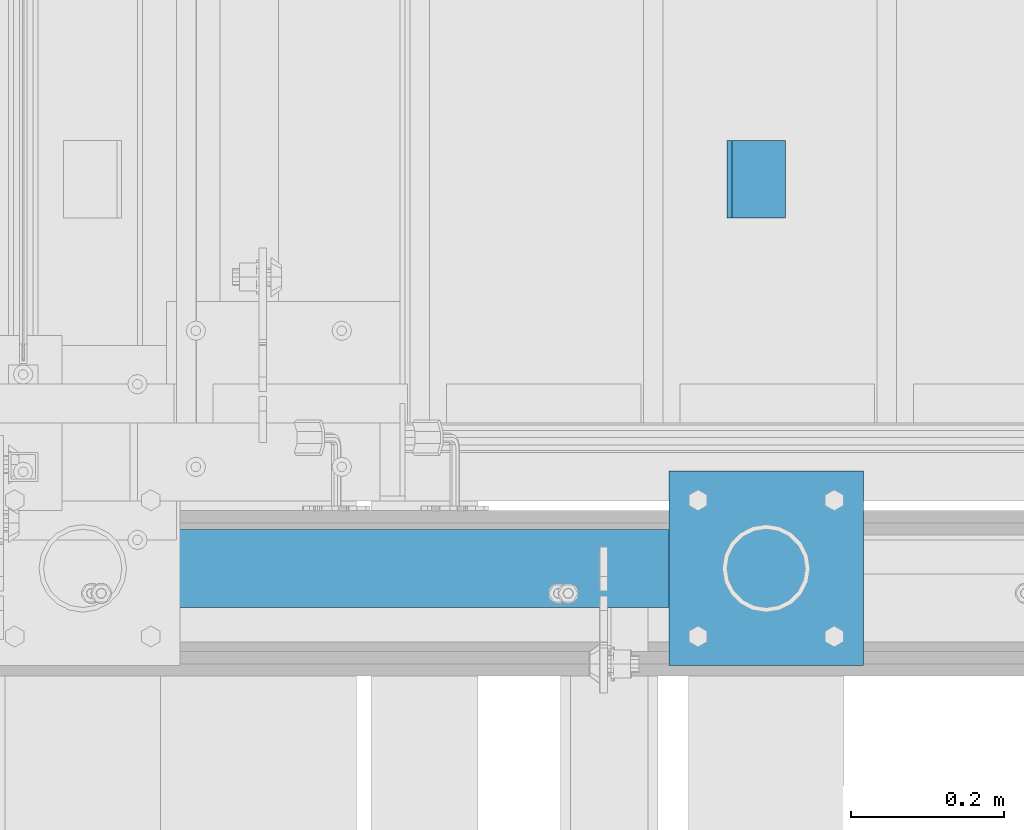
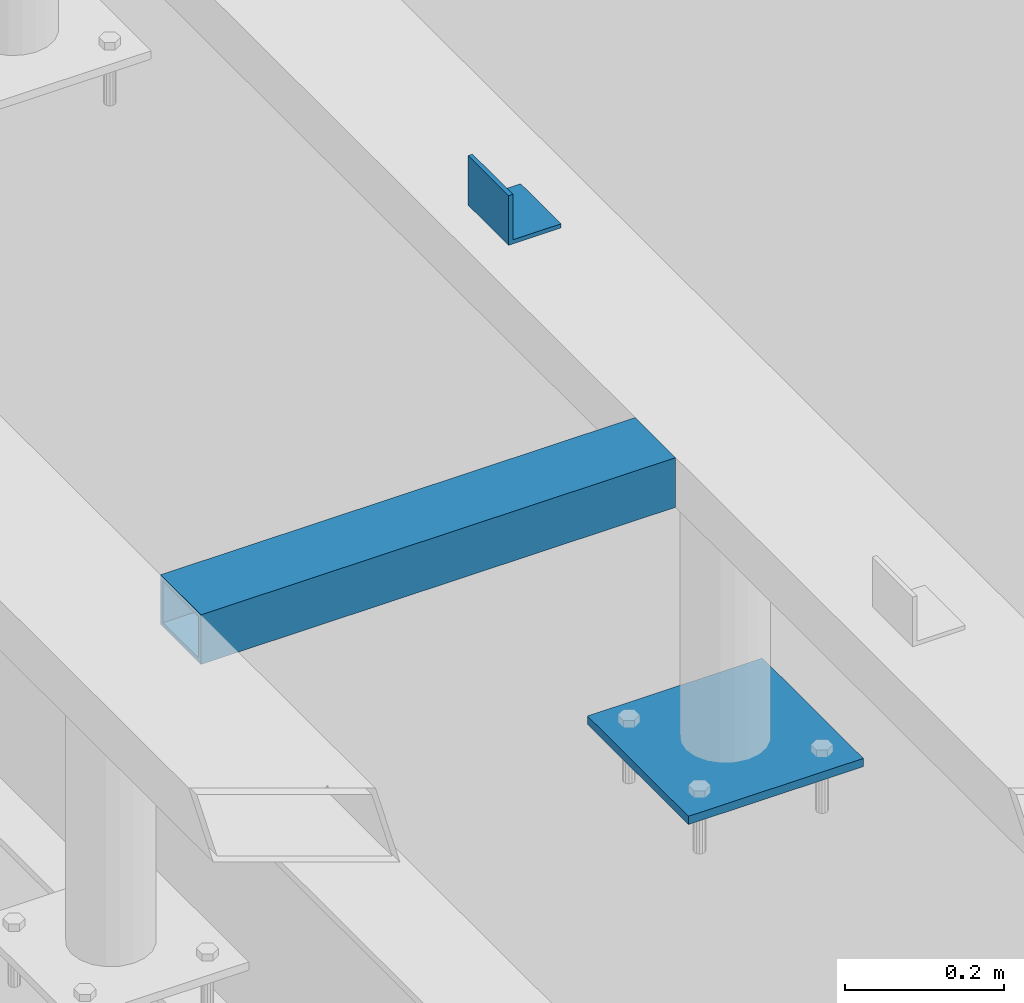
# One storey, part 906 of 1179: 3 beams, 1 element without a shape of its own.
"""IFC2X3 building model written with IfcOpenShell, lengths in millimetres."""

from ifc_helpers import new_model, si_unit, frame, origin_with_axes, place, context, subcontext, project, spatial, faceted_brep, material, type_object, element, aggregate, save


model = new_model("IFC2X3")

# Units and contexts
model_context = context("Model", 3, precision=1e-05, world=origin_with_axes())
body_context = subcontext(model_context, "Body", "Model", "MODEL_VIEW")
ifc_project = project(units=[si_unit("LENGTHUNIT", "METRE", prefix="MILLI"), si_unit("AREAUNIT", "SQUARE_METRE"), si_unit("VOLUMEUNIT", "CUBIC_METRE"), si_unit("MASSUNIT", "GRAM", prefix="KILO"), si_unit("TIMEUNIT", "SECOND"), si_unit("PLANEANGLEUNIT", "RADIAN"), si_unit("SOLIDANGLEUNIT", "STERADIAN"), si_unit("THERMODYNAMICTEMPERATUREUNIT", "DEGREE_CELSIUS"), si_unit("LUMINOUSINTENSITYUNIT", "LUMEN")], contexts=[model_context])

# Site, building, storey
site_placement = place(None, origin_with_axes())
site = spatial("IfcSite", under=ifc_project, at=site_placement, CompositionType="ELEMENT")
building_placement = place(site_placement, origin_with_axes())
building = spatial("IfcBuilding", under=site, at=building_placement, Name="Undefined", CompositionType="ELEMENT")
storey_placement = place(building_placement, origin_with_axes())
storey = spatial("IfcBuildingStorey", under=building, at=storey_placement, Name="Undefined", CompositionType="ELEMENT", Elevation=0.0)

# Assembly, beams
assembly_placement = place(storey_placement, origin_with_axes())
assembly = element("IfcElementAssembly", 1, at=assembly_placement, inside=storey, Name="FRAME", AssemblyPlace="NOTDEFINED", PredefinedType="RIGID_FRAME")
ifc_material_1 = material(Name="STEEL/A36")
beam_type_1 = type_object("IfcBeamType", Name="L3X3X1/4", PredefinedType="NOTDEFINED")
beam_1_placement = place(assembly_placement, frame((20562.8875, 38475.5225542222, 13798.55), z_axis=(0.0, 0.0, 1.0), x_axis=(0.0, 1.0, 0.0)))
beam_1 = element("IfcBeam", 2, at=beam_1_placement, type_object=beam_type_1, material=ifc_material_1, Name="ANGLE", ObjectType="L3X3X1/4", context=body_context, shape_type="Brep", body=[
    faceted_brep([(0.0, 38.0999999999985, -38.0999999999999), (0.0, 38.0999999999985, 38.0999999999999), (101.600000000035, 38.0999999999985, 38.099999999994), (101.599999999962, 38.0999999999985, -38.1000000000058), (0.0, 31.75, 38.1000000000004), (101.600000000035, 31.75, 38.099999999994), (0.0, 31.75, -31.75), (101.599999999969, 31.75, -31.7500000000064), (0.0, -38.0999999999985, -31.75), (101.599999999969, -38.0999999999985, -31.7500000000064), (0.0, -38.0999999999985, -38.0999999999999), (101.599999999962, -38.0999999999985, -38.1000000000058)], [[[0, 1, 2, 3]], [[1, 4, 5, 2]], [[4, 6, 7, 5]], [[6, 8, 9, 7]], [[8, 10, 11, 9]], [[10, 0, 3, 11]], [[5, 7, 9, 11, 3, 2]], [[10, 8, 6, 4, 1, 0]]]),
])
ifc_material_2 = material()
beam_type_2 = type_object("IfcBeamType", Name="HSS4X3X1/4", PredefinedType="NOTDEFINED")
beam_2_placement = place(assembly_placement, frame((19785.0125, 38018.3225542222, 13722.35), z_axis=(0.0, -1.0, 0.0), x_axis=(1.0, 0.0, 0.0)))
beam_2 = element("IfcBeam", 3, at=beam_2_placement, type_object=beam_type_2, material=ifc_material_2, Name="BEAM", ObjectType="HSS4X3X1/4", context=body_context, shape_type="Brep", body=[
    faceted_brep([(0.0, 31.75, -44.4499999999971), (0.0, -31.75, -44.4499999999971), (688.975000000006, -31.75, -44.4499999999971), (688.975000000006, 31.75, -44.4499999999971), (0.0, -31.75, 44.4499999999971), (688.975000000006, -31.75, 44.4499999999971), (0.0, 31.75, 44.4499999999971), (688.975000000006, 31.75, 44.4499999999971), (0.0, 38.0999999999985, -50.8000000000002), (1.45519152283669e-11, 38.1000000000004, 50.8000000000002), (688.975000000006, 38.1000000000004, 50.8000000000029), (688.975000000006, 38.1000000000004, -50.8000000000029), (0.0, -38.0999999999985, 50.8000000000002), (688.975000000006, -38.1000000000004, 50.8000000000029), (0.0, -38.0999999999985, -50.8000000000002), (688.975000000006, -38.1000000000004, -50.8000000000029)], [[[0, 1, 2, 3]], [[1, 4, 5, 2]], [[4, 6, 7, 5]], [[6, 0, 3, 7]], [[8, 9, 10, 11]], [[9, 12, 13, 10]], [[12, 14, 15, 13]], [[14, 8, 11, 15]], [[13, 15, 11, 10], [5, 7, 3, 2]], [[14, 12, 9, 8], [6, 4, 1, 0]]]),
])
beam_type_3 = type_object("IfcBeamType", PredefinedType="NOTDEFINED")
beam_3_placement = place(assembly_placement, frame((20575.5875, 37891.3225542222, 13258.8), z_axis=(1.0, 0.0, 0.0), x_axis=(0.0, 1.0, 0.0)))
beam_3 = element("IfcBeam", 4, at=beam_3_placement, type_object=beam_type_3, material=ifc_material_1, Name="PLATE", context=body_context, shape_type="Brep", body=[
    faceted_brep([(0.0, 6.35000000000036, -127.0), (0.0, 6.34999999999854, 127.0), (254.0, 6.35000000000036, 127.0), (254.0, 6.35000000000036, -127.0), (0.0, -6.34999999999854, 127.0), (254.0, -6.35000000000036, 127.0), (0.0, -6.35000000000036, -127.0), (254.0, -6.35000000000036, -127.0)], [[[0, 1, 2, 3]], [[1, 4, 5, 2]], [[4, 6, 7, 5]], [[6, 0, 3, 7]], [[5, 7, 3, 2]], [[6, 4, 1, 0]]]),
])
aggregate(assembly, [beam_1, beam_2, beam_3])

save(model, "model.ifc")
